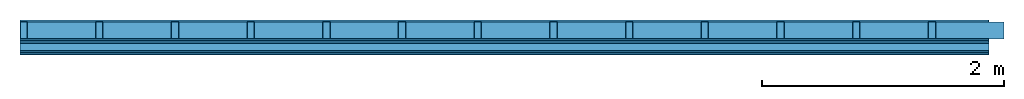
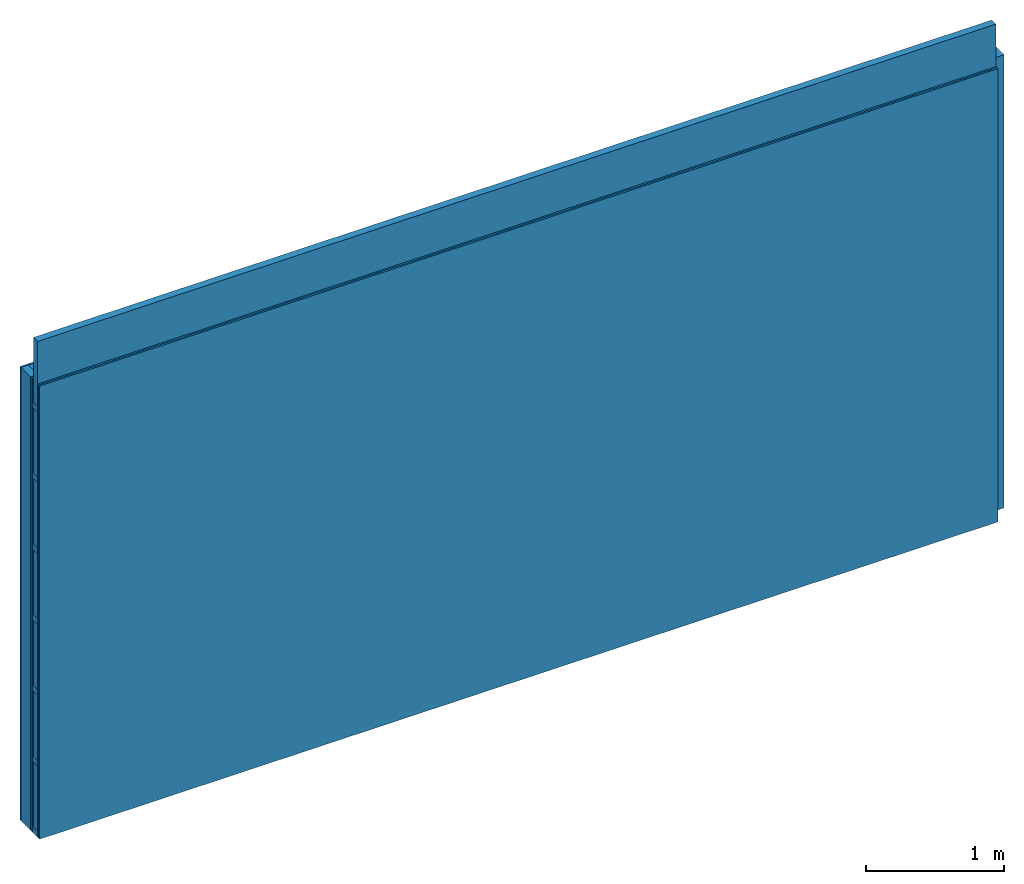
# One storey: 5 plates, 4 members, 1 element without a shape of its own.
"""IFC4 building model written with IfcOpenShell, lengths in metres."""

from ifc_helpers import new_model, si_unit, derived_unit, direction, frame, frame_2d, origin, origin_with_axes, place, context, project, spatial, rectangle, extrude, material, layer, layer_set, type_object, element, aggregate, save


model = new_model("IFC4")

# Units and contexts
plan_context = context("Plan", 3, precision=1e-05, world=origin(), true_north=direction((0.0, 1.0)))
model_context = context("Model", 3, precision=1e-05, world=origin(), true_north=direction((0.0, 1.0)))
ifc_project = project(units=[si_unit("LENGTHUNIT", "METRE"), derived_unit("SOUNDPRESSUREUNIT", [(si_unit("PRESSUREUNIT", "PASCAL", prefix="MICRO"), 0)]), si_unit("ENERGYUNIT", "JOULE", prefix="MEGA"), si_unit("MASSUNIT", "GRAM", prefix="KILO"), derived_unit("THERMALTRANSMITTANCEUNIT", [(si_unit("POWERUNIT", "WATT"), 1), (si_unit("AREAUNIT", "SQUARE_METRE"), -1), (si_unit("THERMODYNAMICTEMPERATUREUNIT", "KELVIN"), -1)]), derived_unit("AREADENSITYUNIT", [(si_unit("MASSUNIT", "GRAM", prefix="KILO"), 1), (si_unit("AREAUNIT", "SQUARE_METRE"), -1)]), derived_unit("USERDEFINED", [(si_unit("ENERGYUNIT", "JOULE", prefix="MEGA"), 1), (si_unit("AREAUNIT", "SQUARE_METRE"), -1)])], contexts=[plan_context, model_context])

# Site, building, storey
site = spatial("IfcSite", under=ifc_project)
building_placement = place(None, origin())
building = spatial("IfcBuilding", under=site, at=building_placement)
storey_placement = place(building_placement, origin())
storey = spatial("IfcBuildingStorey", under=building, at=storey_placement)

# Wall, members, plates
ifc_material_1 = material(Name="Glued joints")
ifc_layer_1 = layer(ifc_material_1, 0.0, Name="Surface")
ifc_material_2 = material(Category="03.007")
ifc_layer_2 = layer(ifc_material_2, 0.015, Name="1st layer")
ifc_material_3 = material(Name="of the art")
ifc_layer_3 = layer(ifc_material_3, 0.0, Name="Bond")
ifc_layer_4 = layer(None, 0.14, Name="Support")
ifc_layer_5 = layer(ifc_material_3, 0.0, Name="Bond")
ifc_layer_6 = layer(ifc_material_2, 0.015, Name="1st layer")
ifc_material_4 = material(Name="Air")
ifc_layer_7 = layer(ifc_material_4, 0.01, Name="Coupling")
ifc_layer_8 = layer(None, 0.075, Name="Battens / profiles")
ifc_layer_9 = layer(ifc_material_2, 0.015, Name="Covering 1st layer")
ifc_layer_10 = layer(ifc_material_2, 0.015, Name="Covering 2nd layer")
ifc_layer_11 = layer(ifc_material_1, 0.0, Name="Surface")
ifc_layer_set = layer_set([ifc_layer_1, ifc_layer_2, ifc_layer_3, ifc_layer_4, ifc_layer_5, ifc_layer_6, ifc_layer_7, ifc_layer_8, ifc_layer_9, ifc_layer_10, ifc_layer_11])
wall_type = type_object("IfcWallType", Name="C0085", PredefinedType="NOTDEFINED", material=ifc_layer_set)
wall_placement = place(None, frame((0.0, 0.0, 0.0), z_axis=(0.0, -1.0, 0.0), x_axis=(1.0, 0.0, 0.0)))
wall = element("IfcWall", 1, at=wall_placement, inside=storey, type_object=wall_type, material=ifc_layer_set, Name="Wall #1")
ifc_material_5 = material()
member_1_placement = place(wall_placement, origin())
member_1 = element("IfcMember", 2, at=member_1_placement, material=ifc_material_5, Name="Support", context=plan_context, shape_type="SweptSolid", body=[
    extrude(rectangle(XDim=0.06, YDim=0.14, at=frame_2d((0.03, 0.07), x_axis=(1.0, 0.0))), frame((0.0, 4.0, 0.015), z_axis=(0.0, -1.0, 0.0), x_axis=(1.0, 0.0, 0.0)), (0.0, 0.0, 1.0), 4.0),
    extrude(rectangle(XDim=0.06, YDim=0.14, at=frame_2d((0.03, 0.07), x_axis=(1.0, 0.0))), frame((0.625, 4.0, 0.015), z_axis=(0.0, -1.0, 0.0), x_axis=(1.0, 0.0, 0.0)), (0.0, 0.0, 1.0), 4.0),
    extrude(rectangle(XDim=0.06, YDim=0.14, at=frame_2d((0.03, 0.07), x_axis=(1.0, 0.0))), frame((1.25, 4.0, 0.015), z_axis=(0.0, -1.0, 0.0), x_axis=(1.0, 0.0, 0.0)), (0.0, 0.0, 1.0), 4.0),
    extrude(rectangle(XDim=0.06, YDim=0.14, at=frame_2d((0.03, 0.07), x_axis=(1.0, 0.0))), frame((1.875, 4.0, 0.015), z_axis=(0.0, -1.0, 0.0), x_axis=(1.0, 0.0, 0.0)), (0.0, 0.0, 1.0), 4.0),
    extrude(rectangle(XDim=0.06, YDim=0.14, at=frame_2d((0.03, 0.07), x_axis=(1.0, 0.0))), frame((2.5, 4.0, 0.015), z_axis=(0.0, -1.0, 0.0), x_axis=(1.0, 0.0, 0.0)), (0.0, 0.0, 1.0), 4.0),
    extrude(rectangle(XDim=0.06, YDim=0.14, at=frame_2d((0.03, 0.07), x_axis=(1.0, 0.0))), frame((3.125, 4.0, 0.015), z_axis=(0.0, -1.0, 0.0), x_axis=(1.0, 0.0, 0.0)), (0.0, 0.0, 1.0), 4.0),
    extrude(rectangle(XDim=0.06, YDim=0.14, at=frame_2d((0.03, 0.07), x_axis=(1.0, 0.0))), frame((3.75, 4.0, 0.015), z_axis=(0.0, -1.0, 0.0), x_axis=(1.0, 0.0, 0.0)), (0.0, 0.0, 1.0), 4.0),
    extrude(rectangle(XDim=0.06, YDim=0.14, at=frame_2d((0.03, 0.07), x_axis=(1.0, 0.0))), frame((4.375, 4.0, 0.015), z_axis=(0.0, -1.0, 0.0), x_axis=(1.0, 0.0, 0.0)), (0.0, 0.0, 1.0), 4.0),
    extrude(rectangle(XDim=0.06, YDim=0.14, at=frame_2d((0.03, 0.07), x_axis=(1.0, 0.0))), frame((5.0, 4.0, 0.015), z_axis=(0.0, -1.0, 0.0), x_axis=(1.0, 0.0, 0.0)), (0.0, 0.0, 1.0), 4.0),
    extrude(rectangle(XDim=0.06, YDim=0.14, at=frame_2d((0.03, 0.07), x_axis=(1.0, 0.0))), frame((5.625, 4.0, 0.015), z_axis=(0.0, -1.0, 0.0), x_axis=(1.0, 0.0, 0.0)), (0.0, 0.0, 1.0), 4.0),
    extrude(rectangle(XDim=0.06, YDim=0.14, at=frame_2d((0.03, 0.07), x_axis=(1.0, 0.0))), frame((6.25, 4.0, 0.015), z_axis=(0.0, -1.0, 0.0), x_axis=(1.0, 0.0, 0.0)), (0.0, 0.0, 1.0), 4.0),
    extrude(rectangle(XDim=0.06, YDim=0.14, at=frame_2d((0.03, 0.07), x_axis=(1.0, 0.0))), frame((6.875, 4.0, 0.015), z_axis=(0.0, -1.0, 0.0), x_axis=(1.0, 0.0, 0.0)), (0.0, 0.0, 1.0), 4.0),
    extrude(rectangle(XDim=0.06, YDim=0.14, at=frame_2d((0.03, 0.07), x_axis=(1.0, 0.0))), frame((7.5, 4.0, 0.015), z_axis=(0.0, -1.0, 0.0), x_axis=(1.0, 0.0, 0.0)), (0.0, 0.0, 1.0), 4.0),
])
ifc_material_6 = material()
member_2_placement = place(wall_placement, origin())
member_2 = element("IfcMember", 3, at=member_2_placement, material=ifc_material_6, Name="Cavity", context=plan_context, shape_type="SweptSolid", body=[
    extrude(rectangle(XDim=0.565, YDim=0.14, at=frame_2d((0.2825, 0.07), x_axis=(1.0, 0.0))), frame((0.06, 4.0, 0.015), z_axis=(0.0, -1.0, 0.0), x_axis=(1.0, 0.0, 0.0)), (0.0, 0.0, 1.0), 4.0),
    extrude(rectangle(XDim=0.565, YDim=0.14, at=frame_2d((0.2825, 0.07), x_axis=(1.0, 0.0))), frame((0.685, 4.0, 0.015), z_axis=(0.0, -1.0, 0.0), x_axis=(1.0, 0.0, 0.0)), (0.0, 0.0, 1.0), 4.0),
    extrude(rectangle(XDim=0.565, YDim=0.14, at=frame_2d((0.2825, 0.07), x_axis=(1.0, 0.0))), frame((1.31, 4.0, 0.015), z_axis=(0.0, -1.0, 0.0), x_axis=(1.0, 0.0, 0.0)), (0.0, 0.0, 1.0), 4.0),
    extrude(rectangle(XDim=0.565, YDim=0.14, at=frame_2d((0.2825, 0.07), x_axis=(1.0, 0.0))), frame((1.935, 4.0, 0.015), z_axis=(0.0, -1.0, 0.0), x_axis=(1.0, 0.0, 0.0)), (0.0, 0.0, 1.0), 4.0),
    extrude(rectangle(XDim=0.565, YDim=0.14, at=frame_2d((0.2825, 0.07), x_axis=(1.0, 0.0))), frame((2.56, 4.0, 0.015), z_axis=(0.0, -1.0, 0.0), x_axis=(1.0, 0.0, 0.0)), (0.0, 0.0, 1.0), 4.0),
    extrude(rectangle(XDim=0.565, YDim=0.14, at=frame_2d((0.2825, 0.07), x_axis=(1.0, 0.0))), frame((3.185, 4.0, 0.015), z_axis=(0.0, -1.0, 0.0), x_axis=(1.0, 0.0, 0.0)), (0.0, 0.0, 1.0), 4.0),
    extrude(rectangle(XDim=0.565, YDim=0.14, at=frame_2d((0.2825, 0.07), x_axis=(1.0, 0.0))), frame((3.81, 4.0, 0.015), z_axis=(0.0, -1.0, 0.0), x_axis=(1.0, 0.0, 0.0)), (0.0, 0.0, 1.0), 4.0),
    extrude(rectangle(XDim=0.565, YDim=0.14, at=frame_2d((0.2825, 0.07), x_axis=(1.0, 0.0))), frame((4.435, 4.0, 0.015), z_axis=(0.0, -1.0, 0.0), x_axis=(1.0, 0.0, 0.0)), (0.0, 0.0, 1.0), 4.0),
    extrude(rectangle(XDim=0.565, YDim=0.14, at=frame_2d((0.2825, 0.07), x_axis=(1.0, 0.0))), frame((5.06, 4.0, 0.015), z_axis=(0.0, -1.0, 0.0), x_axis=(1.0, 0.0, 0.0)), (0.0, 0.0, 1.0), 4.0),
    extrude(rectangle(XDim=0.565, YDim=0.14, at=frame_2d((0.2825, 0.07), x_axis=(1.0, 0.0))), frame((5.685, 4.0, 0.015), z_axis=(0.0, -1.0, 0.0), x_axis=(1.0, 0.0, 0.0)), (0.0, 0.0, 1.0), 4.0),
    extrude(rectangle(XDim=0.565, YDim=0.14, at=frame_2d((0.2825, 0.07), x_axis=(1.0, 0.0))), frame((6.31, 4.0, 0.015), z_axis=(0.0, -1.0, 0.0), x_axis=(1.0, 0.0, 0.0)), (0.0, 0.0, 1.0), 4.0),
    extrude(rectangle(XDim=0.565, YDim=0.14, at=frame_2d((0.2825, 0.07), x_axis=(1.0, 0.0))), frame((6.935, 4.0, 0.015), z_axis=(0.0, -1.0, 0.0), x_axis=(1.0, 0.0, 0.0)), (0.0, 0.0, 1.0), 4.0),
    extrude(rectangle(XDim=0.565, YDim=0.14, at=frame_2d((0.2825, 0.07), x_axis=(1.0, 0.0))), frame((7.56, 4.0, 0.015), z_axis=(0.0, -1.0, 0.0), x_axis=(1.0, 0.0, 0.0)), (0.0, 0.0, 1.0), 4.0),
])
ifc_material_7 = material()
member_3_placement = place(wall_placement, origin())
member_3 = element("IfcMember", 4, at=member_3_placement, material=ifc_material_7, Name="Battens / profiles", context=plan_context, shape_type="SweptSolid", body=[
    extrude(rectangle(XDim=0.05, YDim=0.075, at=frame_2d((0.025, 0.0375), x_axis=(1.0, 0.0))), frame((0.0, 0.0, 0.18), z_axis=(1.0, 0.0, 0.0), x_axis=(0.0, 1.0, 0.0)), (0.0, 0.0, 1.0), 8.0),
    extrude(rectangle(XDim=0.05, YDim=0.075, at=frame_2d((0.025, 0.0375), x_axis=(1.0, 0.0))), frame((0.0, 0.625, 0.18), z_axis=(1.0, 0.0, 0.0), x_axis=(0.0, 1.0, 0.0)), (0.0, 0.0, 1.0), 8.0),
    extrude(rectangle(XDim=0.05, YDim=0.075, at=frame_2d((0.025, 0.0375), x_axis=(1.0, 0.0))), frame((0.0, 1.25, 0.18), z_axis=(1.0, 0.0, 0.0), x_axis=(0.0, 1.0, 0.0)), (0.0, 0.0, 1.0), 8.0),
    extrude(rectangle(XDim=0.05, YDim=0.075, at=frame_2d((0.025, 0.0375), x_axis=(1.0, 0.0))), frame((0.0, 1.875, 0.18), z_axis=(1.0, 0.0, 0.0), x_axis=(0.0, 1.0, 0.0)), (0.0, 0.0, 1.0), 8.0),
    extrude(rectangle(XDim=0.05, YDim=0.075, at=frame_2d((0.025, 0.0375), x_axis=(1.0, 0.0))), frame((0.0, 2.5, 0.18), z_axis=(1.0, 0.0, 0.0), x_axis=(0.0, 1.0, 0.0)), (0.0, 0.0, 1.0), 8.0),
    extrude(rectangle(XDim=0.05, YDim=0.075, at=frame_2d((0.025, 0.0375), x_axis=(1.0, 0.0))), frame((0.0, 3.125, 0.18), z_axis=(1.0, 0.0, 0.0), x_axis=(0.0, 1.0, 0.0)), (0.0, 0.0, 1.0), 8.0),
    extrude(rectangle(XDim=0.05, YDim=0.075, at=frame_2d((0.025, 0.0375), x_axis=(1.0, 0.0))), frame((0.0, 3.75, 0.18), z_axis=(1.0, 0.0, 0.0), x_axis=(0.0, 1.0, 0.0)), (0.0, 0.0, 1.0), 8.0),
])
member_4_placement = place(wall_placement, origin())
member_4 = element("IfcMember", 5, at=member_4_placement, material=ifc_material_6, Name="Cavity", context=plan_context, shape_type="SweptSolid", body=[
    extrude(rectangle(XDim=0.575, YDim=0.06, at=frame_2d((0.2875, 0.03), x_axis=(1.0, 0.0))), frame((0.0, 0.05, 0.195), z_axis=(1.0, 0.0, 0.0), x_axis=(0.0, 1.0, 0.0)), (0.0, 0.0, 1.0), 8.0),
    extrude(rectangle(XDim=0.575, YDim=0.06, at=frame_2d((0.2875, 0.03), x_axis=(1.0, 0.0))), frame((0.0, 0.675, 0.195), z_axis=(1.0, 0.0, 0.0), x_axis=(0.0, 1.0, 0.0)), (0.0, 0.0, 1.0), 8.0),
    extrude(rectangle(XDim=0.575, YDim=0.06, at=frame_2d((0.2875, 0.03), x_axis=(1.0, 0.0))), frame((0.0, 1.3, 0.195), z_axis=(1.0, 0.0, 0.0), x_axis=(0.0, 1.0, 0.0)), (0.0, 0.0, 1.0), 8.0),
    extrude(rectangle(XDim=0.575, YDim=0.06, at=frame_2d((0.2875, 0.03), x_axis=(1.0, 0.0))), frame((0.0, 1.925, 0.195), z_axis=(1.0, 0.0, 0.0), x_axis=(0.0, 1.0, 0.0)), (0.0, 0.0, 1.0), 8.0),
    extrude(rectangle(XDim=0.575, YDim=0.06, at=frame_2d((0.2875, 0.03), x_axis=(1.0, 0.0))), frame((0.0, 2.55, 0.195), z_axis=(1.0, 0.0, 0.0), x_axis=(0.0, 1.0, 0.0)), (0.0, 0.0, 1.0), 8.0),
    extrude(rectangle(XDim=0.575, YDim=0.06, at=frame_2d((0.2875, 0.03), x_axis=(1.0, 0.0))), frame((0.0, 3.175, 0.195), z_axis=(1.0, 0.0, 0.0), x_axis=(0.0, 1.0, 0.0)), (0.0, 0.0, 1.0), 8.0),
    extrude(rectangle(XDim=0.575, YDim=0.06, at=frame_2d((0.2875, 0.03), x_axis=(1.0, 0.0))), frame((0.0, 3.8, 0.195), z_axis=(1.0, 0.0, 0.0), x_axis=(0.0, 1.0, 0.0)), (0.0, 0.0, 1.0), 8.0),
])
plate_1_placement = place(wall_placement, origin())
plate_1 = element("IfcPlate", 6, at=plate_1_placement, material=ifc_material_2, Name="1st layer", context=plan_context, shape_type="SweptSolid", body=[
    extrude(rectangle(XDim=8.0, YDim=4.0, at=frame_2d((4.0, 2.0), x_axis=(1.0, 0.0))), origin_with_axes(), (0.0, 0.0, 1.0), 0.015),
])
plate_2_placement = place(wall_placement, origin())
plate_2 = element("IfcPlate", 7, at=plate_2_placement, material=ifc_material_2, Name="1st layer", context=plan_context, shape_type="SweptSolid", body=[
    extrude(rectangle(XDim=8.0, YDim=4.0, at=frame_2d((4.0, 2.0), x_axis=(1.0, 0.0))), frame((0.0, 0.0, 0.155), z_axis=(0.0, 0.0, 1.0), x_axis=(1.0, 0.0, 0.0)), (0.0, 0.0, 1.0), 0.015),
])
plate_3_placement = place(wall_placement, origin())
plate_3 = element("IfcPlate", 8, at=plate_3_placement, material=ifc_material_4, Name="Coupling", context=plan_context, shape_type="SweptSolid", body=[
    extrude(rectangle(XDim=8.0, YDim=4.0, at=frame_2d((4.0, 2.0), x_axis=(1.0, 0.0))), frame((0.0, 0.0, 0.17), z_axis=(0.0, 0.0, 1.0), x_axis=(1.0, 0.0, 0.0)), (0.0, 0.0, 1.0), 0.01),
])
plate_4_placement = place(wall_placement, origin())
plate_4 = element("IfcPlate", 9, at=plate_4_placement, material=ifc_material_2, Name="Covering 1st layer", context=plan_context, shape_type="SweptSolid", body=[
    extrude(rectangle(XDim=8.0, YDim=4.0, at=frame_2d((4.0, 2.0), x_axis=(1.0, 0.0))), frame((0.0, 0.0, 0.255), z_axis=(0.0, 0.0, 1.0), x_axis=(1.0, 0.0, 0.0)), (0.0, 0.0, 1.0), 0.015),
])
plate_5_placement = place(wall_placement, origin())
plate_5 = element("IfcPlate", 10, at=plate_5_placement, material=ifc_material_2, Name="Covering 2nd layer", context=plan_context, shape_type="SweptSolid", body=[
    extrude(rectangle(XDim=8.0, YDim=4.0, at=frame_2d((4.0, 2.0), x_axis=(1.0, 0.0))), frame((0.0, 0.0, 0.27), z_axis=(0.0, 0.0, 1.0), x_axis=(1.0, 0.0, 0.0)), (0.0, 0.0, 1.0), 0.015),
])
aggregate(wall, [plate_1, member_1, member_2, plate_2, plate_3, member_3, member_4, plate_4, plate_5])

save(model, "model.ifc")
